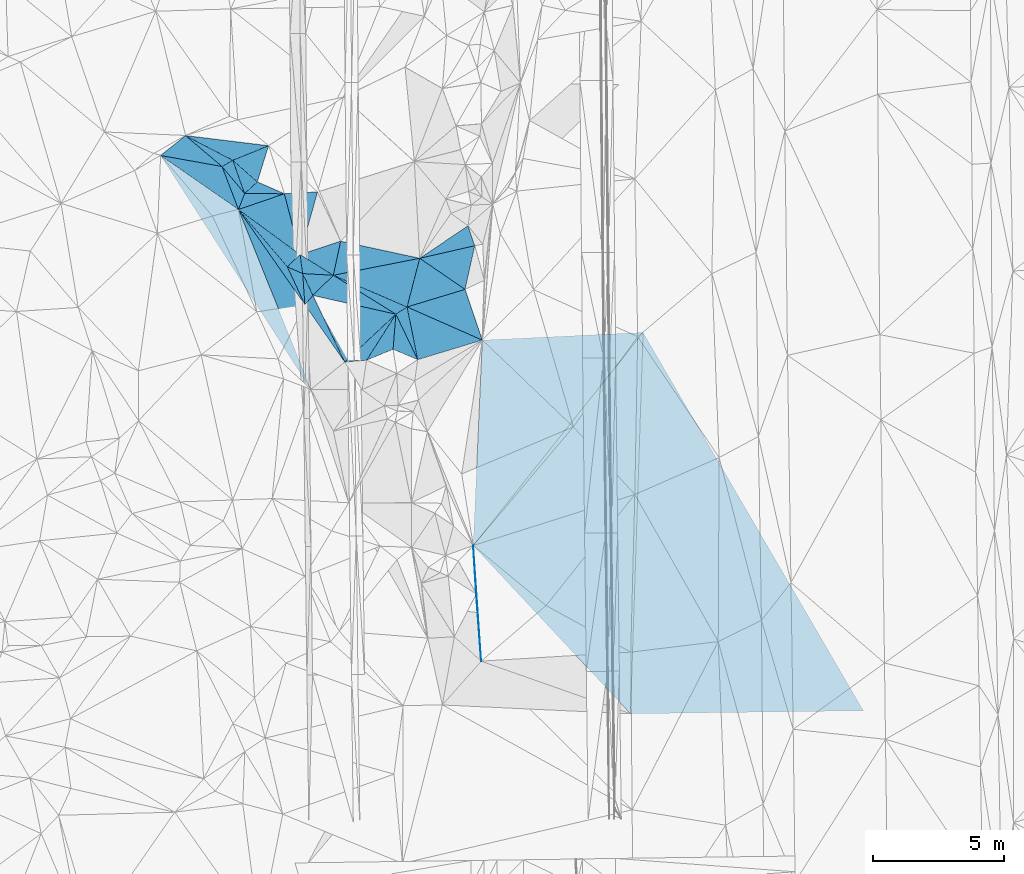
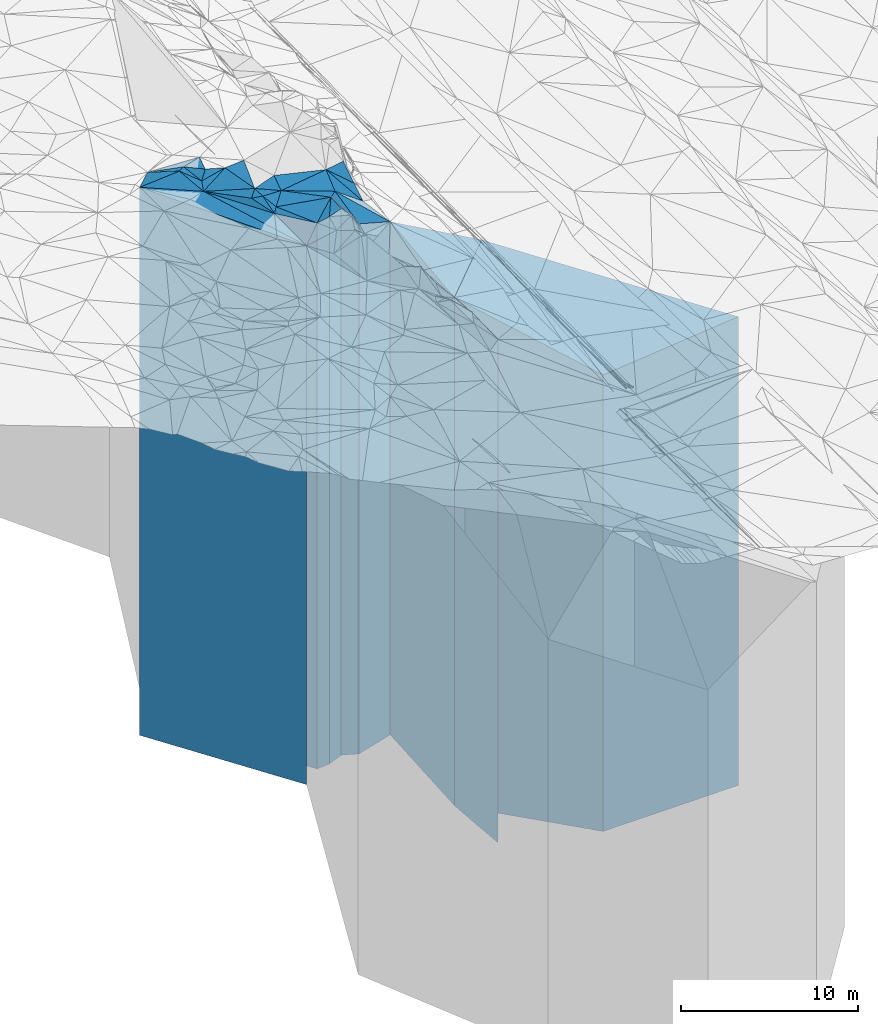
# One storey, part 198 of 275: 41 plates.
"""IFC2X3 building model written with IfcOpenShell, lengths in millimetres."""

from ifc_helpers import new_model, si_unit, frame, origin_with_axes, place, context, subcontext, project, spatial, faceted_brep, material, type_object, element, save


model = new_model("IFC2X3")

# Units and contexts
model_context = context("Model", 3, precision=1e-05, world=origin_with_axes())
body_context = subcontext(model_context, "Body", "Model", "MODEL_VIEW")
ifc_project = project(units=[si_unit("LENGTHUNIT", "METRE", prefix="MILLI"), si_unit("AREAUNIT", "SQUARE_METRE"), si_unit("VOLUMEUNIT", "CUBIC_METRE"), si_unit("MASSUNIT", "GRAM", prefix="KILO"), si_unit("TIMEUNIT", "SECOND"), si_unit("PLANEANGLEUNIT", "RADIAN"), si_unit("SOLIDANGLEUNIT", "STERADIAN"), si_unit("THERMODYNAMICTEMPERATUREUNIT", "DEGREE_CELSIUS"), si_unit("LUMINOUSINTENSITYUNIT", "LUMEN")], contexts=[model_context])

# Site, building, storey
site_placement = place(None, origin_with_axes())
site = spatial("IfcSite", under=ifc_project, at=site_placement, CompositionType="ELEMENT")
building_placement = place(site_placement, origin_with_axes())
building = spatial("IfcBuilding", under=site, at=building_placement, Name="Undefined", CompositionType="ELEMENT")
storey_placement = place(building_placement, origin_with_axes())
storey = spatial("IfcBuildingStorey", under=building, at=storey_placement, Name="Undefined", CompositionType="ELEMENT", Elevation=0.0)

# Plates
ifc_material = material()
plate_type_1 = type_object("IfcPlateType", PredefinedType="NOTDEFINED")
plate_1_placement = place(storey_placement, frame((-92990.5948340277, 5303.93136843647, 23535.0), z_axis=(-0.0129385700025829, 0.99991629319973, 0.0), x_axis=(0.99991629319973, 0.0129385700025844, 0.0)))
element("IfcPlate", 1, at=plate_1_placement, inside=storey, type_object=plate_type_1, material=ifc_material, Name="00", context=body_context, shape_type="Brep", body=[
    faceted_brep([(-1.45519152283669e-11, -15707.0, 1.81898940354586e-12), (667.372558593706, -16052.4609985352, 14508.4794921875), (667.372558593706, 15707.0, 14508.4794921875), (0.0, 15707.0, 0.0), (8868.53906249999, -16553.5419921875, -3.18095771945082e-08), (8868.53906249999, 15707.0, -3.18095771945082e-08)], [[[0, 1, 2, 3]], [[1, 4, 5, 2]], [[4, 0, 3, 5]], [[5, 3, 2]], [[4, 1, 0]]]),
])
plate_type_2 = type_object("IfcPlateType", PredefinedType="NOTDEFINED")
plate_2_placement = place(storey_placement, frame((-107199.470514643, 25551.4387340557, 26891.5), z_axis=(-0.954805034351099, 0.297232815109296, 0.0), x_axis=(0.297232815109295, 0.954805034351099, 0.0)))
element("IfcPlate", 2, at=plate_2_placement, inside=storey, type_object=plate_type_2, material=ifc_material, Name="00", context=body_context, shape_type="Brep", body=[
    faceted_brep([(-5.45696821063757e-12, -19228.5, 2.91038304567337e-11), (508.804626464842, -19208.5, 1135.08496093751), (508.804626464842, 19063.5, 1135.08496093751), (-1.45519152283669e-11, 19063.5, 0.0), (1440.80847167969, -19063.5, -1.01863406598568e-09), (1440.80847167969, 19063.5, -1.01863406598568e-09)], [[[0, 1, 2, 3]], [[1, 4, 5, 2]], [[4, 0, 3, 5]], [[5, 3, 2]], [[4, 1, 0]]]),
])
plate_type_3 = type_object("IfcPlateType", PredefinedType="NOTDEFINED")
plate_3_placement = place(storey_placement, frame((-108132.021914787, 26374.6324452137, 26809.0), z_axis=(-0.376183960948615, 0.926544994873433, 0.0), x_axis=(0.926544994873434, 0.376183960948613, 0.0)))
element("IfcPlate", 3, at=plate_3_placement, inside=storey, type_object=plate_type_3, material=ifc_material, Name="00", context=body_context, shape_type="Brep", body=[
    faceted_brep([(0.0, -19291.0, 0.0), (-1314.03063964844, -18981.0, 1547.46520996094), (-1314.03063964844, 18981.0, 1547.46520996094), (0.0, 18981.0, 0.0), (1468.6895751953, -19146.0, -6.39556674286723e-09), (1468.6895751953, 18981.0, -6.39556674286723e-09)], [[[0, 1, 2, 3]], [[1, 4, 5, 2]], [[4, 0, 3, 5]], [[5, 3, 2]], [[4, 1, 0]]]),
])
plate_type_4 = type_object("IfcPlateType", PredefinedType="NOTDEFINED")
plate_4_placement = place(storey_placement, frame((-108132.021914787, 26374.6324452137, 26809.0), z_axis=(-0.462773634762155, -0.886476487544381, 0.0), x_axis=(-0.886476487544383, 0.462773634762152, 0.0)))
element("IfcPlate", 4, at=plate_4_placement, inside=storey, type_object=plate_type_4, material=ifc_material, Name="00", context=body_context, shape_type="Brep", body=[
    faceted_brep([(0.0, -19291.0, 0.0), (254.011535644546, -19281.0, 398.595214843761), (254.011535644546, 18981.0, 398.595214843761), (0.0, 18981.0, 0.0), (2030.10473632815, -18981.0, 4.12182998843491e-09), (2030.10473632815, 18981.0, 4.12182998843491e-09)], [[[0, 1, 2, 3]], [[1, 4, 5, 2]], [[4, 0, 3, 5]], [[5, 3, 2]], [[4, 1, 0]]]),
])
plate_type_5 = type_object("IfcPlateType", PredefinedType="NOTDEFINED")
plate_5_placement = place(storey_placement, frame((-107915.361007576, 24502.3239633426, 26648.5), z_axis=(-0.933051804347736, 0.359742033134069, 0.0), x_axis=(0.359742033134074, 0.933051804347734, 0.0)))
element("IfcPlate", 5, at=plate_5_placement, inside=storey, type_object=plate_type_5, material=ifc_material, Name="00", context=body_context, shape_type="Brep", body=[
    faceted_brep([(-5.45696821063757e-12, -18820.5, 1.45519152283669e-11), (1301.64660644531, -19441.5, 1173.08874511719), (1301.64660644531, 18820.5, 1173.08874511719), (-5.45696821063757e-12, 18820.5, 1.45519152283669e-11), (649.831542968741, -19091.5, -1.01863406598568e-10), (649.831542968741, 18820.5, -1.01863406598568e-10)], [[[0, 1, 2, 3]], [[1, 4, 5, 2]], [[4, 0, 3, 5]], [[5, 3, 2]], [[4, 1, 0]]]),
])
plate_type_6 = type_object("IfcPlateType", PredefinedType="NOTDEFINED")
plate_6_placement = place(storey_placement, frame((-107199.470514643, 25551.4387340557, 26784.0), z_axis=(0.676426673879136, -0.736509982868398, 0.0), x_axis=(-0.736509982868399, -0.676426673879136, 0.0)))
element("IfcPlate", 6, at=plate_6_placement, inside=storey, type_object=plate_type_6, material=ifc_material, Name="00", context=body_context, shape_type="Brep", body=[
    faceted_brep([(0.0, -19336.0, -1.45519152283669e-11), (-453.560028076172, -19336.0, 1029.94335937501), (-453.560028076172, 18956.0, 1029.94335937501), (0.0, 18956.0, -1.45519152283669e-11), (654.599121093735, -18956.0, 3.91446519643068e-09), (654.599121093735, 18956.0, 3.91446519643068e-09)], [[[0, 1, 2, 3]], [[1, 4, 5, 2]], [[4, 0, 3, 5]], [[5, 3, 2]], [[4, 1, 0]]]),
])
plate_type_7 = type_object("IfcPlateType", PredefinedType="NOTDEFINED")
plate_7_placement = place(storey_placement, frame((-104907.550578569, 25165.3001493106, 26859.0), z_axis=(0.051963891019074, -0.998648964366437, 0.0), x_axis=(-0.998648964366438, -0.051963891019069, 0.0)))
element("IfcPlate", 7, at=plate_7_placement, inside=storey, type_object=plate_type_7, material=ifc_material, Name="00", context=body_context, shape_type="Brep", body=[
    faceted_brep([(0.0, -19301.0, 0.0), (786.368774414063, -19031.0, 2344.0615234375), (786.368774414063, 19031.0, 2344.0615234375), (0.0, 19031.0, 7.27595761418343e-12), (1262.8935546875, -19261.0, 7.39237293601036e-09), (1262.8935546875, 19031.0, 7.39237293601036e-09)], [[[0, 1, 2, 3]], [[1, 4, 5, 2]], [[4, 0, 3, 5]], [[5, 3, 2]], [[4, 1, 0]]]),
])
plate_type_8 = type_object("IfcPlateType", PredefinedType="NOTDEFINED")
plate_8_placement = place(storey_placement, frame((-98919.875575369, 23122.1780149173, 25724.0), z_axis=(0.222518969878509, -0.974928360467685, 0.0), x_axis=(-0.974928360467686, -0.222518969878503, 0.0)))
element("IfcPlate", 8, at=plate_8_placement, inside=storey, type_object=plate_type_8, material=ifc_material, Name="00", context=body_context, shape_type="Brep", body=[
    faceted_brep([(0.0, -18006.0, 0.0), (730.135131835952, -17896.0, 1537.49877929688), (730.135131835952, 17896.0, 1537.49877929688), (0.0, 17896.0, 0.0), (2149.46508789063, -19956.0, -1.70257408171892e-09), (2149.46508789063, 17896.0, -1.70257408171892e-09)], [[[0, 1, 2, 3]], [[1, 4, 5, 2]], [[4, 0, 3, 5]], [[5, 3, 2]], [[4, 1, 0]]]),
])
plate_type_9 = type_object("IfcPlateType", PredefinedType="NOTDEFINED")
plate_9_placement = place(storey_placement, frame((-104305.392508007, 21998.2975193692, 26654.0), z_axis=(0.39502921906975, 0.918668556162201, 0.0), x_axis=(0.918668556162203, -0.395029219069747, 0.0)))
element("IfcPlate", 9, at=plate_9_placement, inside=storey, type_object=plate_type_9, material=ifc_material, Name="00", context=body_context, shape_type="Brep", body=[
    faceted_brep([(-1.45519152283669e-11, -19126.0, -7.27595761418343e-12), (2767.34228515624, -19026.0, 1892.70092773437), (2767.34228515624, 18826.0, 1892.70092773437), (-1.45519152283669e-11, 18826.0, -7.27595761418343e-12), (3056.79565429688, -18826.0, 1.47229002323002e-08), (3056.79565429688, 18826.0, 1.47229002323002e-08)], [[[0, 1, 2, 3]], [[1, 4, 5, 2]], [[4, 0, 3, 5]], [[5, 3, 2]], [[4, 1, 0]]]),
])
plate_type_10 = type_object("IfcPlateType", PredefinedType="NOTDEFINED")
plate_10_placement = place(storey_placement, frame((-108132.021914787, 26374.6324452137, 26784.0), z_axis=(0.498877389055066, -0.866672574095662, 0.0), x_axis=(-0.866672574095666, -0.498877389055059, 0.0)))
element("IfcPlate", 10, at=plate_10_placement, inside=storey, type_object=plate_type_10, material=ifc_material, Name="00", context=body_context, shape_type="Brep", body=[
    faceted_brep([(0.0, -19316.0, -1.45519152283669e-11), (241.192199707046, -18956.0, 1321.90258789061), (241.192199707046, 18956.0, 1321.90258789061), (0.0, 18956.0, -1.45519152283669e-11), (472.652099609375, -19306.0, -2.75031197816134e-09), (472.652099609375, 18956.0, -2.75031197816134e-09)], [[[0, 1, 2, 3]], [[1, 4, 5, 2]], [[4, 0, 3, 5]], [[5, 3, 2]], [[4, 1, 0]]]),
])
plate_type_11 = type_object("IfcPlateType", PredefinedType="NOTDEFINED")
plate_11_placement = place(storey_placement, frame((-107681.589296681, 25108.6504324873, 26784.0), z_axis=(-0.676426673879136, 0.736509982868398, 0.0), x_axis=(0.7365099828684, 0.676426673879135, 0.0)))
element("IfcPlate", 11, at=plate_11_placement, inside=storey, type_object=plate_type_11, material=ifc_material, Name="00", context=body_context, shape_type="Brep", body=[
    faceted_brep([(-7.27595761418343e-12, -18956.0, 0.0), (524.595886230469, -19316.0, 1237.09301757813), (524.595886230469, 18956.0, 1237.09301757813), (0.0, 18956.0, -1.45519152283669e-11), (654.59912109375, -19336.0, 3.89991328120232e-09), (654.599121093735, 18956.0, 3.91446519643068e-09)], [[[0, 1, 2, 3]], [[1, 4, 5, 2]], [[4, 0, 3, 5]], [[5, 3, 2]], [[4, 1, 0]]]),
])
plate_type_12 = type_object("IfcPlateType", PredefinedType="NOTDEFINED")
plate_12_placement = place(storey_placement, frame((-101015.450012272, 22643.8812666528, 25724.0), z_axis=(0.967828550671313, -0.251610604914552, 0.0), x_axis=(-0.251610604914551, -0.967828550671313, 0.0)))
element("IfcPlate", 12, at=plate_12_placement, inside=storey, type_object=plate_type_12, material=ifc_material, Name="00", context=body_context, shape_type="Brep", body=[
    faceted_brep([(3.63797880709171e-12, -19956.0, 1.45519152283669e-11), (710.81402587891, -17896.0, 1968.03039550783), (710.81402587891, 17896.0, 1968.03039550783), (0.0, 17896.0, 0.0), (1914.70629882813, -19756.0, -1.35332811623812e-09), (1914.70629882813, 17896.0, -1.35332811623812e-09)], [[[0, 1, 2, 3]], [[1, 4, 5, 2]], [[4, 0, 3, 5]], [[5, 3, 2]], [[4, 1, 0]]]),
])
plate_type_13 = type_object("IfcPlateType", PredefinedType="NOTDEFINED")
plate_13_placement = place(storey_placement, frame((-99289.582390574, 21460.7578781695, 25489.0), z_axis=(0.290406667931243, -0.956903321773455, 0.0), x_axis=(-0.956903321773454, -0.290406667931246, 0.0)))
element("IfcPlate", 13, at=plate_13_placement, inside=storey, type_object=plate_type_13, material=ifc_material, Name="00", context=body_context, shape_type="Brep", body=[
    faceted_brep([(-1.45519152283669e-11, -18131.0, 0.0), (-67.076873779326, -17661.0, 2039.93884277344), (-67.076873779326, 17661.0, 2039.93884277344), (-2.91038304567337e-11, 17661.0, 1.45519152283669e-11), (2307.05444335936, -19991.0, 1.84809323400259e-09), (2307.05444335936, 17661.0, 1.84809323400259e-09)], [[[0, 1, 2, 3]], [[1, 4, 5, 2]], [[4, 0, 3, 5]], [[5, 3, 2]], [[4, 1, 0]]]),
])
plate_type_14 = type_object("IfcPlateType", PredefinedType="NOTDEFINED")
plate_14_placement = place(storey_placement, frame((-107915.361007576, 24502.3239633426, 26648.5), z_axis=(0.591278657076204, 0.806467327103932, 0.0), x_axis=(0.806467327103934, -0.591278657076202, 0.0)))
element("IfcPlate", 14, at=plate_14_placement, inside=storey, type_object=plate_type_14, material=ifc_material, Name="00", context=body_context, shape_type="Brep", body=[
    faceted_brep([(-5.45696821063757e-12, -18820.5, 1.45519152283669e-11), (1055.39343261719, -19471.5, 1514.48535156249), (1055.39343261719, 18820.5, 1514.48535156249), (-5.45696821063757e-12, 18820.5, 1.45519152283669e-11), (2906.88842773438, -19241.5, 1.39334588311613e-08), (2906.88842773438, 18820.5, 1.39334588311613e-08)], [[[0, 1, 2, 3]], [[1, 4, 5, 2]], [[4, 0, 3, 5]], [[5, 3, 2]], [[4, 1, 0]]]),
])
plate_type_15 = type_object("IfcPlateType", PredefinedType="NOTDEFINED")
plate_15_placement = place(storey_placement, frame((-104024.721101112, 23292.331352525, 26804.0), z_axis=(0.312546317051192, -0.949902521155584, 0.0), x_axis=(-0.949902521155585, -0.312546317051191, 0.0)))
element("IfcPlate", 15, at=plate_15_placement, inside=storey, type_object=plate_type_15, material=ifc_material, Name="00", context=body_context, shape_type="Brep", body=[
    faceted_brep([(0.0, -19136.0, 0.0), (671.055969238267, -18976.0, 1141.48315429688), (671.055969238267, 18976.0, 1141.48315429688), (0.0, 18976.0, 0.0), (1627.88208007814, -19086.0, -3.8635334931314e-09), (1627.88208007814, 18976.0, -3.8635334931314e-09)], [[[0, 1, 2, 3]], [[1, 4, 5, 2]], [[4, 0, 3, 5]], [[5, 3, 2]], [[4, 1, 0]]]),
])
plate_type_16 = type_object("IfcPlateType", PredefinedType="NOTDEFINED")
plate_16_placement = place(storey_placement, frame((-105470.889756957, 22062.4548469964, 26799.0), z_axis=(0.0549639590025308, 0.998488339045964, 0.0), x_axis=(0.998488339045964, -0.0549639590025311, 0.0)))
element("IfcPlate", 16, at=plate_16_placement, inside=storey, type_object=plate_type_16, material=ifc_material, Name="00", context=body_context, shape_type="Brep", body=[
    faceted_brep([(0.0, -18971.0, 0.0), (-139.643051147475, -19091.0, 714.49267578125), (-139.643051147475, 18971.0, 714.49267578125), (0.0, 18971.0, 0.0), (1167.26171875, -18981.0, 6.56291376799345e-09), (1167.26171875, 18971.0, 6.56291376799345e-09)], [[[0, 1, 2, 3]], [[1, 4, 5, 2]], [[4, 0, 3, 5]], [[5, 3, 2]], [[4, 1, 0]]]),
])
plate_type_17 = type_object("IfcPlateType", PredefinedType="NOTDEFINED")
plate_17_placement = place(storey_placement, frame((-101090.834766413, 18783.6717983929, 25489.0), z_axis=(-0.289914033933249, 0.957052690779641, 0.0), x_axis=(0.957052690779641, 0.289914033933248, 0.0)))
element("IfcPlate", 17, at=plate_17_placement, inside=storey, type_object=plate_type_17, material=ifc_material, Name="00", context=body_context, shape_type="Brep", body=[
    faceted_brep([(0.0, -18821.0, 0.0), (192.964157104492, -19991.0, 2038.71643066407), (192.964157104492, 17661.0, 2038.71643066407), (-2.91038304567337e-11, 17661.0, 1.45519152283669e-11), (2568.14526367188, -17661.0, -6.54836185276508e-11), (2568.14526367188, 17661.0, -6.54836185276508e-11)], [[[0, 1, 2, 3]], [[1, 4, 5, 2]], [[4, 0, 3, 5]], [[5, 3, 2]], [[4, 1, 0]]]),
])
plate_type_18 = type_object("IfcPlateType", PredefinedType="NOTDEFINED")
plate_18_placement = place(storey_placement, frame((-105080.553508909, 21229.1256122641, 26609.0), z_axis=(0.220416258902142, 0.975405901566924, 0.0), x_axis=(0.975405901566925, -0.220416258902136, 0.0)))
element("IfcPlate", 18, at=plate_18_placement, inside=storey, type_object=plate_type_18, material=ifc_material, Name="00", context=body_context, shape_type="Brep", body=[
    faceted_brep([(-1.45519152283669e-11, -18791.0, 4.54747350886464e-13), (586.55859375, -19171.0, 921.112915039067), (586.55859375, 18781.0, 921.112915039067), (-1.45519152283669e-11, 18781.0, 4.54747350886464e-13), (3238.03955078124, -18781.0, 2.07551238418091e-08), (3238.03955078124, 18781.0, 2.07551238418091e-08)], [[[0, 1, 2, 3]], [[1, 4, 5, 2]], [[4, 0, 3, 5]], [[5, 3, 2]], [[4, 1, 0]]]),
])
plate_type_19 = type_object("IfcPlateType", PredefinedType="NOTDEFINED")
plate_19_placement = place(storey_placement, frame((-101015.450012272, 22643.8812666528, 26754.0), z_axis=(-0.210649019965134, -0.977561757838209, 0.0), x_axis=(-0.977561757838208, 0.210649019965137, 0.0)))
element("IfcPlate", 19, at=plate_19_placement, inside=storey, type_object=plate_type_19, material=ifc_material, Name="00", context=body_context, shape_type="Brep", body=[
    faceted_brep([(7.27595761418343e-12, -18926.0, 1.45519152283669e-11), (3080.13037109376, -19026.0, 1324.12109375), (3080.13037109376, 18926.0, 1324.12109375), (7.27595761418343e-12, 18926.0, 1.45519152283669e-11), (3078.34375000001, -19186.0, -1.33582034322899e-09), (3078.34375000001, 18926.0, -1.33582034322899e-09)], [[[0, 1, 2, 3]], [[1, 4, 5, 2]], [[4, 0, 3, 5]], [[5, 3, 2]], [[4, 1, 0]]]),
])
plate_type_20 = type_object("IfcPlateType", PredefinedType="NOTDEFINED")
plate_20_placement = place(storey_placement, frame((-106054.227069006, 22318.4188686318, 26545.0), z_axis=(0.907572443178826, 0.419895535082736, 0.0), x_axis=(0.419895535082733, -0.907572443178827, 0.0)))
element("IfcPlate", 20, at=plate_20_placement, inside=storey, type_object=plate_type_20, material=ifc_material, Name="00", context=body_context, shape_type="Brep", body=[
    faceted_brep([(0.0, -19125.0, 1.45519152283669e-11), (477.246612548828, -19225.0, 421.942718505874), (477.246612548828, 18717.0, 421.942718505874), (0.0, 18717.0, 1.45519152283669e-11), (1587.22961425781, -18717.0, 5.89352566748858e-09), (1587.22961425781, 18717.0, 5.89352566748858e-09)], [[[0, 1, 2, 3]], [[1, 4, 5, 2]], [[4, 0, 3, 5]], [[5, 3, 2]], [[4, 1, 0]]]),
])
plate_type_21 = type_object("IfcPlateType", PredefinedType="NOTDEFINED")
plate_21_placement = place(storey_placement, frame((-106168.737867491, 25099.6752892141, 26648.5), z_axis=(-0.00593249599756627, -0.999982402590785, 0.0), x_axis=(-0.999982402590785, 0.00593249599757254, 0.0)))
element("IfcPlate", 21, at=plate_21_placement, inside=storey, type_object=plate_type_21, material=ifc_material, Name="00", context=body_context, shape_type="Brep", body=[
    faceted_brep([(-7.27595761418343e-12, -19471.5, -1.45519152283669e-11), (1743.04858398439, -18820.5, 607.702636718754), (1743.04858398439, 18820.5, 607.702636718754), (-5.45696821063757e-12, 18820.5, 1.45519152283669e-11), (1512.87805175783, -19091.5, -8.94942786544561e-09), (1512.87805175783, 18820.5, -8.94942786544561e-09)], [[[0, 1, 2, 3]], [[1, 4, 5, 2]], [[4, 0, 3, 5]], [[5, 3, 2]], [[4, 1, 0]]]),
])
plate_type_22 = type_object("IfcPlateType", PredefinedType="NOTDEFINED")
plate_22_placement = place(storey_placement, frame((-105387.756420146, 20877.892966675, 26545.0), z_axis=(-0.752710129173302, 0.658352080151579, 0.0), x_axis=(0.658352080151573, 0.752710129173307, 0.0)))
element("IfcPlate", 22, at=plate_22_placement, inside=storey, type_object=plate_type_22, material=ifc_material, Name="00", context=body_context, shape_type="Brep", body=[
    faceted_brep([(-2.18278728425503e-11, -18717.0, 2.91038304567337e-11), (836.900695800759, -19225.0, 842.434082031265), (836.900695800759, 18717.0, 842.434082031265), (0.0, 18717.0, 1.45519152283669e-11), (466.624053955071, -18855.0, 1.32422428578138e-09), (466.624053955071, 18717.0, 1.32422428578138e-09)], [[[0, 1, 2, 3]], [[1, 4, 5, 2]], [[4, 0, 3, 5]], [[5, 3, 2]], [[4, 1, 0]]]),
])
plate_type_23 = type_object("IfcPlateType", PredefinedType="NOTDEFINED")
plate_23_placement = place(storey_placement, frame((-104305.392508007, 21998.2975193692, 26614.0), z_axis=(-0.0549639590025308, -0.998488339045964, 0.0), x_axis=(-0.998488339045964, 0.0549639590025304, 0.0)))
element("IfcPlate", 23, at=plate_23_placement, inside=storey, type_object=plate_type_23, material=ifc_material, Name="00", context=body_context, shape_type="Brep", body=[
    faceted_brep([(0.0, -19166.0, -1.81898940354586e-12), (731.712463378921, -18786.0, 810.615112304684), (731.712463378921, 18786.0, 810.615112304684), (0.0, 18786.0, -1.81898940354586e-12), (1167.26171875, -19156.0, 6.55927578918636e-09), (1167.26171875, 18786.0, 6.55927578918636e-09)], [[[0, 1, 2, 3]], [[1, 4, 5, 2]], [[4, 0, 3, 5]], [[5, 3, 2]], [[4, 1, 0]]]),
])
plate_type_24 = type_object("IfcPlateType", PredefinedType="NOTDEFINED")
plate_24_placement = place(storey_placement, frame((-103039.325023073, 18764.0320504265, 26609.0), z_axis=(-0.37908068696638, 0.925363621917945, 0.0), x_axis=(0.925363621917943, 0.379080686966385, 0.0)))
element("IfcPlate", 24, at=plate_24_placement, inside=storey, type_object=plate_type_24, material=ifc_material, Name="00", context=body_context, shape_type="Brep", body=[
    faceted_brep([(-1.45519152283669e-11, -18891.0, 0.0), (1697.70568847653, -18781.0, 1197.16137695313), (1697.70568847653, 18781.0, 1197.16137695313), (-1.45519152283669e-11, 18781.0, 4.54747350886464e-13), (1090.41271972655, -18841.0, -5.0931703299284e-10), (1090.41271972655, 18781.0, -5.0931703299284e-10)], [[[0, 1, 2, 3]], [[1, 4, 5, 2]], [[4, 0, 3, 5]], [[5, 3, 2]], [[4, 1, 0]]]),
])
plate_type_25 = type_object("IfcPlateType", PredefinedType="NOTDEFINED")
plate_25_placement = place(storey_placement, frame((-106054.227069006, 22318.4188686318, 26545.0), z_axis=(-0.761110686961941, -0.64862201796757, 0.0), x_axis=(-0.648622017967568, 0.761110686961943, 0.0)))
element("IfcPlate", 25, at=plate_25_placement, inside=storey, type_object=plate_type_25, material=ifc_material, Name="00", context=body_context, shape_type="Brep", body=[
    faceted_brep([(0.0, -19125.0, 1.45519152283669e-11), (-1528.68725585936, -18717.0, 427.09887695311), (-1528.68725585936, 18717.0, 427.09887695311), (0.0, 18717.0, 1.45519152283669e-11), (2869.36596679688, -18924.0, 3.65253072232008e-09), (2869.36596679688, 18717.0, 3.65253072232008e-09)], [[[0, 1, 2, 3]], [[1, 4, 5, 2]], [[4, 0, 3, 5]], [[5, 3, 2]], [[4, 1, 0]]]),
])
plate_type_26 = type_object("IfcPlateType", PredefinedType="NOTDEFINED")
plate_26_placement = place(storey_placement, frame((-103871.033273747, 18691.4966400278, 26609.0), z_axis=(-0.0868827749992972, 0.996218541991877, 0.0), x_axis=(0.996218541991878, 0.0868827749992902, 0.0)))
element("IfcPlate", 26, at=plate_26_placement, inside=storey, type_object=plate_type_26, material=ifc_material, Name="00", context=body_context, shape_type="Brep", body=[
    faceted_brep([(-1.45519152283669e-11, -18791.0, 4.54747350886464e-13), (2099.97949218749, -18781.0, 1647.69104003907), (2099.97949218749, 18781.0, 1647.69104003907), (-1.45519152283669e-11, 18781.0, 4.54747350886464e-13), (834.865234375, -18891.0, -5.51153789274395e-09), (834.865234375, 18781.0, -5.51153789274395e-09)], [[[0, 1, 2, 3]], [[1, 4, 5, 2]], [[4, 0, 3, 5]], [[5, 3, 2]], [[4, 1, 0]]]),
])
plate_type_27 = type_object("IfcPlateType", PredefinedType="NOTDEFINED")
plate_27_placement = place(storey_placement, frame((-101922.150641701, 20515.4090519897, 26609.0), z_axis=(-0.220416258902142, -0.975405901566924, 0.0), x_axis=(-0.975405901566925, 0.220416258902137, 0.0)))
element("IfcPlate", 27, at=plate_27_placement, inside=storey, type_object=plate_type_27, material=ifc_material, Name="00", context=body_context, shape_type="Brep", body=[
    faceted_brep([(1.45519152283669e-11, -18781.0, 4.54747350886464e-12), (1498.931640625, -18791.0, 2208.62036132813), (1498.931640625, 18781.0, 2208.62036132813), (-1.45519152283669e-11, 18781.0, 4.54747350886464e-13), (3238.03955078126, -18791.0, 2.07592165679671e-08), (3238.03955078124, 18781.0, 2.07551238418091e-08)], [[[0, 1, 2, 3]], [[1, 4, 5, 2]], [[4, 0, 3, 5]], [[5, 3, 2]], [[4, 1, 0]]]),
])
plate_type_28 = type_object("IfcPlateType", PredefinedType="NOTDEFINED")
plate_28_placement = place(storey_placement, frame((-105080.553508909, 21229.1256122641, 26545.0), z_axis=(0.752710129173302, -0.658352080151579, 0.0), x_axis=(-0.658352080151571, -0.752710129173309, 0.0)))
element("IfcPlate", 28, at=plate_28_placement, inside=storey, type_object=plate_type_28, material=ifc_material, Name="00", context=body_context, shape_type="Brep", body=[
    faceted_brep([(0.0, -18855.0, -1.45519152283669e-11), (1113.8088378906, -18855.0, 2581.07153320313), (1113.8088378906, 18717.0, 2581.07153320313), (0.0, 18717.0, 1.45519152283669e-11), (466.624053955078, -18717.0, 1.28056854009628e-09), (466.624053955071, 18717.0, 1.32422428578138e-09)], [[[0, 1, 2, 3]], [[1, 4, 5, 2]], [[4, 0, 3, 5]], [[5, 3, 2]], [[4, 1, 0]]]),
])
plate_type_29 = type_object("IfcPlateType", PredefinedType="NOTDEFINED")
plate_29_placement = place(storey_placement, frame((-99179.3717224447, 23882.1528497986, 25779.0), z_axis=(0.559137393063282, -0.829075012093838, 0.0), x_axis=(-0.829075012093836, -0.559137393063285, 0.0)))
element("IfcPlate", 29, at=plate_29_placement, inside=storey, type_object=plate_type_29, material=ifc_material, Name="00", context=body_context, shape_type="Brep", body=[
    faceted_brep([(-1.45519152283669e-11, -19091.0, 0.0), (209.788574218735, -17951.0, 775.170166015625), (209.788574218735, 17951.0, 775.170166015625), (-1.45519152283669e-11, 17951.0, 0.0), (2214.61059570311, -19901.0, -2.00816430151463e-09), (2214.61059570311, 17951.0, -2.00816430151463e-09)], [[[0, 1, 2, 3]], [[1, 4, 5, 2]], [[4, 0, 3, 5]], [[5, 3, 2]], [[4, 1, 0]]]),
])
plate_type_30 = type_object("IfcPlateType", PredefinedType="NOTDEFINED")
plate_30_placement = place(storey_placement, frame((-98862.9012135535, 9862.63979060135, 25152.0), z_axis=(0.997272765521643, 0.0738040049645991, 0.0), x_axis=(0.0738040049645991, -0.997272765521643, 0.0)))
element("IfcPlate", 30, at=plate_30_placement, inside=storey, type_object=plate_type_30, material=ifc_material, Name="00", context=body_context, shape_type="Brep", body=[
    faceted_brep([(1.45519152283669e-11, -17668.0, -1.45519152283669e-11), (-1845.3984375, -17635.0, 21.5803775787354), (-1845.3984375, 17324.0, 21.5803775787354), (1.45519152283669e-11, 17324.0, -1.45519152283669e-11), (2567.05444335938, -17324.0, 2.95403879135847e-09), (2567.05444335938, 17324.0, 2.95403879135847e-09)], [[[0, 1, 2, 3]], [[1, 4, 5, 2]], [[4, 0, 3, 5]], [[5, 3, 2]], [[4, 1, 0]]]),
])
plate_type_31 = type_object("IfcPlateType", PredefinedType="NOTDEFINED")
plate_31_placement = place(storey_placement, frame((-104305.392508007, 21998.2975193692, 26609.0), z_axis=(0.528297370813101, 0.849059413699633, 0.0), x_axis=(0.84905941369963, -0.528297370813106, 0.0)))
element("IfcPlate", 31, at=plate_31_placement, inside=storey, type_object=plate_type_31, material=ifc_material, Name="00", context=body_context, shape_type="Brep", body=[
    faceted_brep([(-1.45519152283669e-11, -19171.0, 0.0), (3022.24511718749, -18871.0, 458.295928955078), (3022.24511718749, 18781.0, 458.295928955078), (-1.45519152283669e-11, 18781.0, 4.54747350886464e-13), (2806.91992187499, -18781.0, -4.78758011013269e-09), (2806.91992187499, 18781.0, -4.78758011013269e-09)], [[[0, 1, 2, 3]], [[1, 4, 5, 2]], [[4, 0, 3, 5]], [[5, 3, 2]], [[4, 1, 0]]]),
])
plate_type_32 = type_object("IfcPlateType", PredefinedType="NOTDEFINED")
plate_32_placement = place(storey_placement, frame((-101922.150641701, 20515.4090519897, 26069.0), z_axis=(0.996749552569862, -0.0805625809652322, 0.0), x_axis=(-0.0805625809652292, -0.996749552569863, 0.0)))
element("IfcPlate", 32, at=plate_32_placement, inside=storey, type_object=plate_type_32, material=ifc_material, Name="00", context=body_context, shape_type="Brep", body=[
    faceted_brep([(0.0, -19321.0, 0.0), (1659.13537597656, -18241.0, 968.126953124985), (1659.13537597656, 18241.0, 968.126953124985), (0.0, 18241.0, 0.0), (1342.38598632812, -19381.0, 5.0931703299284e-10), (1342.38598632812, 18241.0, 5.0931703299284e-10)], [[[0, 1, 2, 3]], [[1, 4, 5, 2]], [[4, 0, 3, 5]], [[5, 3, 2]], [[4, 1, 0]]]),
])
plate_type_33 = type_object("IfcPlateType", PredefinedType="NOTDEFINED")
plate_33_placement = place(storey_placement, frame((-92510.9970998416, 19819.8308669145, 23535.0), z_axis=(0.782071093514746, -0.623189220613329, 0.0), x_axis=(-0.623189220613328, -0.782071093514747, 0.0)))
element("IfcPlate", 33, at=plate_33_placement, inside=storey, type_object=plate_type_33, material=ifc_material, Name="00", context=body_context, shape_type="Brep", body=[
    faceted_brep([(7.27595761418343e-12, -16052.4609985352, -1.45519152283669e-11), (11651.345703125, -15707.0, 8671.072265625), (11651.345703125, 15707.0, 8671.072265625), (0.0, 15707.0, 0.0), (10376.591796875, -19252.4609375, 1.74331944435835e-08), (10376.591796875, 15707.0, 1.74331944435835e-08)], [[[0, 1, 2, 3]], [[1, 4, 5, 2]], [[4, 0, 3, 5]], [[5, 3, 2]], [[4, 1, 0]]]),
])
plate_type_34 = type_object("IfcPlateType", PredefinedType="NOTDEFINED")
plate_34_placement = place(storey_placement, frame((-108541.656519952, 26138.8370036747, 26648.5), z_axis=(-0.176587342053257, -0.984284974296858, 0.0), x_axis=(-0.984284974296858, 0.176587342053258, 0.0)))
element("IfcPlate", 34, at=plate_34_placement, inside=storey, type_object=plate_type_34, material=ifc_material, Name="00", context=body_context, shape_type="Brep", body=[
    faceted_brep([(0.0, -19441.5, 0.0), (-905.440734863281, -18820.5, 1500.19934082031), (-905.440734863281, 18820.5, 1500.19934082031), (-5.45696821063757e-12, 18820.5, 1.45519152283669e-11), (2376.93090820311, -18894.5, -1.67929101735353e-08), (2376.93090820311, 18820.5, -1.67929101735353e-08)], [[[0, 1, 2, 3]], [[1, 4, 5, 2]], [[4, 0, 3, 5]], [[5, 3, 2]], [[4, 1, 0]]]),
])
plate_type_35 = type_object("IfcPlateType", PredefinedType="NOTDEFINED")
plate_35_placement = place(storey_placement, frame((-105571.050373719, 22783.5428103199, 26749.0), z_axis=(0.693519966794825, -0.720437405786863, 0.0), x_axis=(-0.72043740578686, -0.693519966794828, 0.0)))
element("IfcPlate", 35, at=plate_35_placement, inside=storey, type_object=plate_type_35, material=ifc_material, Name="00", context=body_context, shape_type="Brep", body=[
    faceted_brep([(0.0, -19141.0, 0.0), (427.929443359382, -19021.0, 588.96215820311), (427.929443359382, 18921.0, 588.96215820311), (0.0, 18921.0, 0.0), (670.671325683594, -18921.0, -3.30328475683928e-09), (670.671325683594, 18921.0, -3.30328475683928e-09)], [[[0, 1, 2, 3]], [[1, 4, 5, 2]], [[4, 0, 3, 5]], [[5, 3, 2]], [[4, 1, 0]]]),
])
plate_type_36 = type_object("IfcPlateType", PredefinedType="NOTDEFINED")
plate_36_placement = place(storey_placement, frame((-105161.285860759, 17653.0207078513, 26372.5), z_axis=(-0.927804706294666, -0.373066250118486, 0.0), x_axis=(-0.373066250118484, 0.927804706294667, 0.0)))
element("IfcPlate", 36, at=plate_36_placement, inside=storey, type_object=plate_type_36, material=ifc_material, Name="00", context=body_context, shape_type="Brep", body=[
    faceted_brep([(-1.45519152283669e-11, -18544.5, 0.0), (10396.533203125, -19170.5, 1984.6336669922), (10396.533203125, 18544.5, 1984.6336669922), (-1.45519152283669e-11, 18544.5, 0.0), (7382.26806640626, -19096.5, -2.64117261394858e-08), (7382.26806640626, 18544.5, -2.64117261394858e-08)], [[[0, 1, 2, 3]], [[1, 4, 5, 2]], [[4, 0, 3, 5]], [[5, 3, 2]], [[4, 1, 0]]]),
])
plate_type_37 = type_object("IfcPlateType", PredefinedType="NOTDEFINED")
plate_37_placement = place(storey_placement, frame((-108541.656519952, 26138.8370036747, 26685.5), z_axis=(-0.645659151786558, -0.76362573274757, 0.0), x_axis=(-0.763625732747568, 0.64565915178656, 0.0)))
element("IfcPlate", 37, at=plate_37_placement, inside=storey, type_object=plate_type_37, material=ifc_material, Name="00", context=body_context, shape_type="Brep", body=[
    faceted_brep([(1.45519152283669e-11, -19404.5, 7.27595761418343e-12), (2057.56762695314, -18857.5, 1190.04833984376), (2057.56762695314, 18857.5, 1190.04833984376), (1.45519152283669e-11, 18857.5, 7.27595761418343e-12), (1820.27062988283, -19104.5, -1.52795109897852e-10), (1820.27062988283, 18857.5, -1.52795109897852e-10)], [[[0, 1, 2, 3]], [[1, 4, 5, 2]], [[4, 0, 3, 5]], [[5, 3, 2]], [[4, 1, 0]]]),
])
plate_type_38 = type_object("IfcPlateType", PredefinedType="NOTDEFINED")
plate_38_placement = place(storey_placement, frame((-107915.361007576, 24502.3239633426, 26648.5), z_axis=(0.761110686961941, 0.64862201796757, 0.0), x_axis=(0.648622017967566, -0.761110686961944, 0.0)))
element("IfcPlate", 38, at=plate_38_placement, inside=storey, type_object=plate_type_38, material=ifc_material, Name="00", context=body_context, shape_type="Brep", body=[
    faceted_brep([(-5.45696821063757e-12, -18820.5, 1.45519152283669e-11), (2828.75415039064, -19241.5, 669.440551757798), (2828.75415039064, 18820.5, 669.440551757798), (-5.45696821063757e-12, 18820.5, 1.45519152283669e-11), (2869.36596679688, -19021.5, 3.62342689186335e-09), (2869.36596679688, 18820.5, 3.62342689186335e-09)], [[[0, 1, 2, 3]], [[1, 4, 5, 2]], [[4, 0, 3, 5]], [[5, 3, 2]], [[4, 1, 0]]]),
])
plate_type_39 = type_object("IfcPlateType", PredefinedType="NOTDEFINED")
plate_39_placement = place(storey_placement, frame((-101497.210408615, 20790.7738977951, 26069.0), z_axis=(0.543812874714481, -0.83920650455938, 0.0), x_axis=(-0.839206504559387, -0.54381287471447, 0.0)))
element("IfcPlate", 39, at=plate_39_placement, inside=storey, type_object=plate_type_39, material=ifc_material, Name="00", context=body_context, shape_type="Brep", body=[
    faceted_brep([(1.45519152283669e-11, -19411.0, -1.45519152283669e-11), (750.454895019546, -18241.0, 1905.36547851561), (750.454895019546, 18241.0, 1905.36547851561), (0.0, 18241.0, 0.0), (506.359558105483, -19321.0, -1.45519152283669e-09), (506.359558105483, 18241.0, -1.45519152283669e-09)], [[[0, 1, 2, 3]], [[1, 4, 5, 2]], [[4, 0, 3, 5]], [[5, 3, 2]], [[4, 1, 0]]]),
])
plate_type_40 = type_object("IfcPlateType", PredefinedType="NOTDEFINED")
plate_40_placement = place(storey_placement, frame((-105161.285860759, 17653.0207078513, 26372.5), z_axis=(-0.99754322301253, -0.0700536810008811, 0.0), x_axis=(-0.0700536810008791, 0.997543223012531, 0.0)))
element("IfcPlate", 40, at=plate_40_placement, inside=storey, type_object=plate_type_40, material=ifc_material, Name="00", context=body_context, shape_type="Brep", body=[
    faceted_brep([(-1.45519152283669e-11, -18544.5, 0.0), (7025.40917968751, -19096.5, 2267.48999023438), (7025.40917968751, 18544.5, 2267.48999023438), (-1.45519152283669e-11, 18544.5, 0.0), (3232.814453125, -18889.5, -2.09547579288483e-09), (3232.814453125, 18544.5, -2.09547579288483e-09)], [[[0, 1, 2, 3]], [[1, 4, 5, 2]], [[4, 0, 3, 5]], [[5, 3, 2]], [[4, 1, 0]]]),
])
plate_type_41 = type_object("IfcPlateType", PredefinedType="NOTDEFINED")
plate_41_placement = place(storey_placement, frame((-92510.9970998416, 19819.8308669145, 23707.5), z_axis=(0.0475805359957717, -0.99886740491136, 0.0), x_axis=(-0.99886740491136, -0.0475805359957777, 0.0)))
element("IfcPlate", 41, at=plate_41_placement, inside=storey, type_object=plate_type_41, material=ifc_material, Name="00", context=body_context, shape_type="Brep", body=[
    faceted_brep([(-1.45519152283669e-11, -15879.5, -3.63797880709171e-12), (6845.38330078121, -19079.5, 7798.35791015625), (6845.38330078121, 15879.5, 7798.35791015625), (3.63797880709171e-12, 15879.5, 0.0), (6128.9287109375, -19442.5, -1.0590156307444e-08), (6128.9287109375, 15879.5, -1.0590156307444e-08)], [[[0, 1, 2, 3]], [[1, 4, 5, 2]], [[4, 0, 3, 5]], [[5, 3, 2]], [[4, 1, 0]]]),
])

save(model, "model.ifc")
